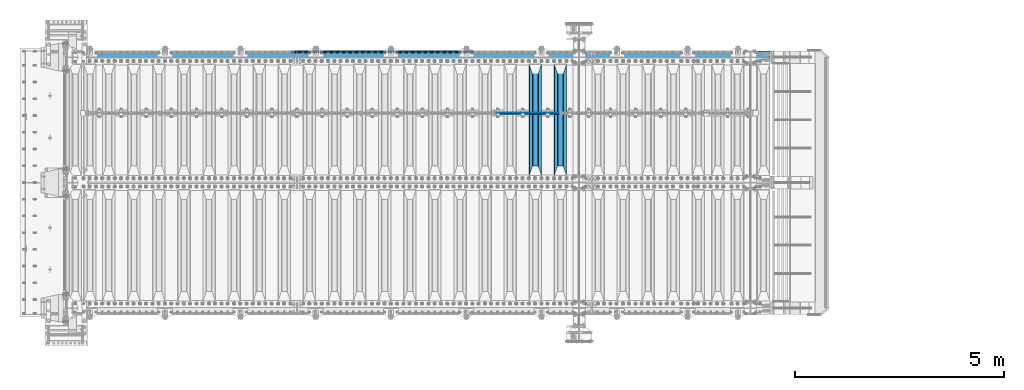
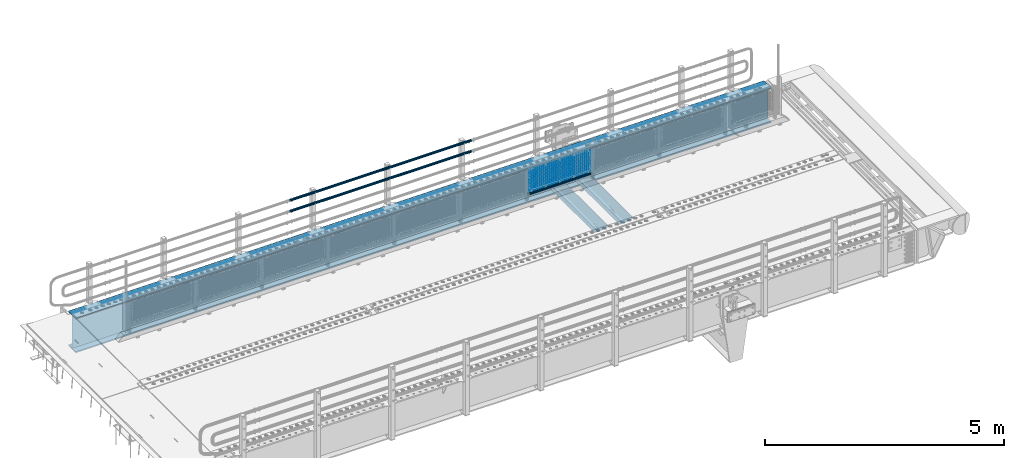
# One storey, part 105 of 208: 23 beams.
"""IFC2X3 building model written with IfcOpenShell, lengths in millimetres."""

from ifc_helpers import new_model, si_unit, frame, origin_with_axes, place, context, subcontext, project, spatial, faceted_brep, material, type_object, element, save


model = new_model("IFC2X3")

# Units and contexts
model_context = context("Model", 3, precision=1e-05, world=origin_with_axes())
body_context = subcontext(model_context, "Body", "Model", "MODEL_VIEW")
ifc_project = project(units=[si_unit("LENGTHUNIT", "METRE", prefix="MILLI"), si_unit("AREAUNIT", "SQUARE_METRE"), si_unit("VOLUMEUNIT", "CUBIC_METRE"), si_unit("MASSUNIT", "GRAM", prefix="KILO"), si_unit("TIMEUNIT", "SECOND"), si_unit("PLANEANGLEUNIT", "RADIAN"), si_unit("SOLIDANGLEUNIT", "STERADIAN"), si_unit("THERMODYNAMICTEMPERATUREUNIT", "DEGREE_CELSIUS"), si_unit("LUMINOUSINTENSITYUNIT", "LUMEN")], contexts=[model_context])

# Site, building, storey
site_placement = place(None, origin_with_axes())
site = spatial("IfcSite", under=ifc_project, at=site_placement, CompositionType="ELEMENT")
building_placement = place(site_placement, origin_with_axes())
building = spatial("IfcBuilding", under=site, at=building_placement, Name="Standard", CompositionType="ELEMENT")
storey_placement = place(building_placement, origin_with_axes())
storey = spatial("IfcBuildingStorey", under=building, at=storey_placement, Name="Undefined", CompositionType="ELEMENT", Elevation=0.0)

# Beams
ifc_material_1 = material(Name="STEEL/S355N")
beam_type_1 = type_object("IfcBeamType", PredefinedType="NOTDEFINED")
beam_1_placement = place(storey_placement, frame((-30650.0, 3175.0, -115.0), z_axis=(0.0, 0.0, 1.0), x_axis=(0.0, 1.0, 0.0)))
element("IfcBeam", 1, at=beam_1_placement, inside=storey, type_object=beam_type_1, material=ifc_material_1, context=body_context, shape_type="Brep", body=[
    faceted_brep([(0.0, 150.0, 115.0), (0.0, 143.689999999999, 115.0), (2650.00000000297, 143.689999999999, 115.0), (2650.00000000297, 150.0, 115.0), (2650.00000000297, 142.059565218402, 110.0000000031), (2650.00000000297, 148.369565218403, 110.0000000031), (2441.90079219208, -80.1103600731112, -98.0992078077845), (2437.7588105432, -77.5672621345584, -102.241189456673), (2434.06523489746, -74.4080125315522, -105.934765102404), (2430.91086095089, -70.710272125576, -109.089139048974), (2428.37322971128, -66.5649389910068, -111.626770288588), (2426.51472138055, -62.0739139532889, -113.485278619323), (2425.38102192091, -57.3475956567672, -114.618978078955), (2424.99999999987, -52.5021667386536, -115.0), (2424.99999999987, 52.5021667386536, -115.0), (2425.38102192091, 57.3475956567672, -114.618978078955), (2426.51472138055, 62.0739139532889, -113.485278619323), (2428.37322971128, 66.5649389910068, -111.626770288588), (2430.91086095089, 70.710272125576, -109.089139048974), (2434.06523489746, 74.4080125315522, -105.934765102404), (2437.7588105432, 77.5672621345584, -102.241189456673), (2441.90079219208, 80.1103600731112, -98.0992078077846), (2446.38936140511, 81.9747917625791, -93.6106385947584), (2448.24948500409, 76.2713538057251, -91.7505149957729), (2444.62967112262, 74.76777986261, -95.3703288772456), (2441.28936334126, 72.7168944282894, -98.710636658607), (2438.31067330438, 70.1691124903846, -101.689326695487), (2435.76682334747, 67.1870637758839, -104.233176652398), (2433.72034654133, 63.8440531834895, -106.279653458539), (2432.22154950041, 60.222258798236, -107.778450499454), (2431.30727574265, 56.4107117849089, -108.692724257221), (2430.99999999987, 52.5031078186876, -109.0), (2430.99999999987, -52.5031078186876, -109.0), (2431.30727574265, -56.4107117849089, -108.692724257221), (2432.22154950041, -60.222258798236, -107.778450499454), (2433.72034654133, -63.8440531834895, -106.279653458539), (2435.76682334747, -67.1870637758839, -104.233176652398), (2438.31067330438, -70.1691124903846, -101.689326695487), (2441.28936334126, -72.7168944282894, -98.7106366586071), (2444.62967112262, -74.76777986261, -95.3703288772457), (2448.24948500409, -76.2713538057251, -91.7505149957729), (2650.00000000297, -142.059565218402, 110.0000000031), (2650.00000000297, -148.369565218403, 110.0000000031), (2446.38936140511, -81.9747917625791, -93.6106385947584), (2650.00000000297, -143.689999999999, 115.0), (2650.00000000297, -150.0, 115.0), (0.0, -143.689999999999, 115.0), (0.0, -150.0, 115.0), (0.0, -148.369565218261, 110.000000002663), (203.610638597421, -81.9747917625791, -93.6106385947584), (208.099207810448, -80.1103600731112, -98.0992078077845), (212.241189459336, -77.5672621345584, -102.241189456673), (215.934765105067, -74.4080125315522, -105.934765102404), (219.089139051637, -70.710272125576, -109.089139048974), (221.626770291251, -66.5649389910068, -111.626770288588), (223.485278621986, -62.0739139532889, -113.485278619323), (224.618978081618, -57.3475956567672, -114.618978078955), (225.000000002663, -52.5021667386536, -115.0), (225.000000002663, 52.5021667386536, -115.0), (224.618978081618, 57.3475956567672, -114.618978078955), (223.485278621986, 62.0739139532889, -113.485278619323), (221.626770291251, 66.5649389910068, -111.626770288588), (219.089139051637, 70.710272125576, -109.089139048974), (215.934765105067, 74.4080125315522, -105.934765102404), (212.241189459336, 77.5672621345584, -102.241189456673), (208.099207810448, 80.1103600731112, -98.0992078077846), (203.610638597421, 81.9747917625791, -93.6106385947584), (0.0, 148.369565218261, 110.000000002663), (0.0, 142.05956521826, 110.000000002663), (201.750514998436, 76.2713538057251, -91.7505149957729), (205.370328879908, 74.76777986261, -95.3703288772456), (208.71063666127, 72.7168944282894, -98.710636658607), (211.68932669815, 70.1691124903846, -101.689326695487), (214.233176655061, 67.1870637758839, -104.233176652398), (216.279653461202, 63.8440531834895, -106.279653458539), (217.778450502116, 60.222258798236, -107.778450499454), (218.692724259884, 56.4107117849089, -108.692724257221), (219.000000002663, 52.5031078186876, -109.0), (219.000000002663, -52.5031078186876, -109.0), (218.692724259884, -56.4107117849089, -108.692724257221), (217.778450502116, -60.222258798236, -107.778450499454), (216.279653461202, -63.8440531834895, -106.279653458539), (214.233176655061, -67.1870637758839, -104.233176652398), (211.68932669815, -70.1691124903846, -101.689326695487), (208.71063666127, -72.7168944282894, -98.7106366586071), (205.370328879908, -74.76777986261, -95.3703288772457), (201.750514998436, -76.2713538057251, -91.7505149957729), (0.0, -142.05956521826, 110.000000002663)], [[[0, 1, 2, 3]], [[3, 2, 4, 5]], [[6, 7, 8, 9, 10, 11, 12, 13, 14, 15, 16, 17, 18, 19, 20, 21, 22, 5, 4, 23, 24, 25, 26, 27, 28, 29, 30, 31, 32, 33, 34, 35, 36, 37, 38, 39, 40, 41, 42, 43]], [[44, 45, 42, 41]], [[46, 47, 45, 44]], [[43, 42, 45, 47, 48, 49]], [[6, 43, 49, 50]], [[7, 6, 50, 51]], [[8, 7, 51, 52]], [[9, 8, 52, 53]], [[10, 9, 53, 54]], [[11, 10, 54, 55]], [[12, 11, 55, 56]], [[13, 12, 56, 57]], [[14, 13, 57, 58]], [[15, 14, 58, 59]], [[16, 15, 59, 60]], [[17, 16, 60, 61]], [[18, 17, 61, 62]], [[19, 18, 62, 63]], [[20, 19, 63, 64]], [[21, 20, 64, 65]], [[22, 21, 65, 66]], [[0, 3, 5, 22, 66, 67]], [[1, 0, 67, 68]], [[23, 4, 2, 1, 68, 69]], [[24, 23, 69, 70]], [[25, 24, 70, 71]], [[26, 25, 71, 72]], [[27, 26, 72, 73]], [[28, 27, 73, 74]], [[29, 28, 74, 75]], [[30, 29, 75, 76]], [[31, 30, 76, 77]], [[32, 31, 77, 78]], [[33, 32, 78, 79]], [[34, 33, 79, 80]], [[35, 34, 80, 81]], [[36, 35, 81, 82]], [[37, 36, 82, 83]], [[38, 37, 83, 84]], [[39, 38, 84, 85]], [[40, 39, 85, 86]], [[46, 44, 41, 40, 86, 87]], [[47, 46, 87, 48]], [[86, 85, 84, 83, 82, 81, 80, 79, 78, 77, 76, 75, 74, 73, 72, 71, 70, 69, 68, 67, 66, 65, 64, 63, 62, 61, 60, 59, 58, 57, 56, 55, 54, 53, 52, 51, 50, 49, 48, 87]]]),
])
beam_2_placement = place(storey_placement, frame((-31250.0, 3175.0, -115.0), z_axis=(0.0, 0.0, 1.0), x_axis=(0.0, 1.0, 0.0)))
element("IfcBeam", 2, at=beam_2_placement, inside=storey, type_object=beam_type_1, material=ifc_material_1, context=body_context, shape_type="Brep", body=[
    faceted_brep([(0.0, 150.0, 115.0), (0.0, 143.689999999999, 115.0), (2650.00000000297, 143.689999999999, 115.0), (2650.00000000297, 150.0, 115.0), (2650.00000000297, 142.059565218402, 110.0000000031), (2650.00000000297, 148.369565218403, 110.0000000031), (2441.90079219208, -80.1103600731112, -98.0992078077845), (2437.7588105432, -77.5672621345584, -102.241189456673), (2434.06523489746, -74.4080125315522, -105.934765102404), (2430.91086095089, -70.710272125576, -109.089139048974), (2428.37322971128, -66.5649389910068, -111.626770288588), (2426.51472138055, -62.0739139532889, -113.485278619323), (2425.38102192091, -57.3475956567672, -114.618978078955), (2424.99999999987, -52.5021667386536, -115.0), (2424.99999999987, 52.5021667386536, -115.0), (2425.38102192091, 57.3475956567672, -114.618978078955), (2426.51472138055, 62.0739139532889, -113.485278619323), (2428.37322971128, 66.5649389910068, -111.626770288588), (2430.91086095089, 70.710272125576, -109.089139048974), (2434.06523489746, 74.4080125315522, -105.934765102404), (2437.7588105432, 77.5672621345584, -102.241189456673), (2441.90079219208, 80.1103600731112, -98.0992078077846), (2446.38936140511, 81.9747917625791, -93.6106385947584), (2448.24948500409, 76.2713538057251, -91.7505149957729), (2444.62967112262, 74.76777986261, -95.3703288772456), (2441.28936334126, 72.7168944282894, -98.710636658607), (2438.31067330438, 70.1691124903846, -101.689326695487), (2435.76682334747, 67.1870637758839, -104.233176652398), (2433.72034654133, 63.8440531834895, -106.279653458539), (2432.22154950041, 60.222258798236, -107.778450499454), (2431.30727574265, 56.4107117849089, -108.692724257221), (2430.99999999987, 52.5031078186876, -109.0), (2430.99999999987, -52.5031078186876, -109.0), (2431.30727574265, -56.4107117849089, -108.692724257221), (2432.22154950041, -60.222258798236, -107.778450499454), (2433.72034654133, -63.8440531834895, -106.279653458539), (2435.76682334747, -67.1870637758839, -104.233176652398), (2438.31067330438, -70.1691124903846, -101.689326695487), (2441.28936334126, -72.7168944282894, -98.7106366586071), (2444.62967112262, -74.76777986261, -95.3703288772457), (2448.24948500409, -76.2713538057251, -91.7505149957729), (2650.00000000297, -142.059565218402, 110.0000000031), (2650.00000000297, -148.369565218403, 110.0000000031), (2446.38936140511, -81.9747917625791, -93.6106385947584), (2650.00000000297, -143.689999999999, 115.0), (2650.00000000297, -150.0, 115.0), (0.0, -143.689999999999, 115.0), (0.0, -150.0, 115.0), (0.0, -148.369565218261, 110.000000002663), (203.610638597421, -81.9747917625791, -93.6106385947584), (208.099207810448, -80.1103600731112, -98.0992078077845), (212.241189459336, -77.5672621345584, -102.241189456673), (215.934765105067, -74.4080125315522, -105.934765102404), (219.089139051637, -70.710272125576, -109.089139048974), (221.626770291251, -66.5649389910068, -111.626770288588), (223.485278621986, -62.0739139532889, -113.485278619323), (224.618978081618, -57.3475956567672, -114.618978078955), (225.000000002663, -52.5021667386536, -115.0), (225.000000002663, 52.5021667386536, -115.0), (224.618978081618, 57.3475956567672, -114.618978078955), (223.485278621986, 62.0739139532889, -113.485278619323), (221.626770291251, 66.5649389910068, -111.626770288588), (219.089139051637, 70.710272125576, -109.089139048974), (215.934765105067, 74.4080125315522, -105.934765102404), (212.241189459336, 77.5672621345584, -102.241189456673), (208.099207810448, 80.1103600731112, -98.0992078077846), (203.610638597421, 81.9747917625791, -93.6106385947584), (0.0, 148.369565218261, 110.000000002663), (0.0, 142.05956521826, 110.000000002663), (201.750514998436, 76.2713538057251, -91.7505149957729), (205.370328879908, 74.76777986261, -95.3703288772456), (208.71063666127, 72.7168944282894, -98.710636658607), (211.68932669815, 70.1691124903846, -101.689326695487), (214.233176655061, 67.1870637758839, -104.233176652398), (216.279653461202, 63.8440531834895, -106.279653458539), (217.778450502116, 60.222258798236, -107.778450499454), (218.692724259884, 56.4107117849089, -108.692724257221), (219.000000002663, 52.5031078186876, -109.0), (219.000000002663, -52.5031078186876, -109.0), (218.692724259884, -56.4107117849089, -108.692724257221), (217.778450502116, -60.222258798236, -107.778450499454), (216.279653461202, -63.8440531834895, -106.279653458539), (214.233176655061, -67.1870637758839, -104.233176652398), (211.68932669815, -70.1691124903846, -101.689326695487), (208.71063666127, -72.7168944282894, -98.7106366586071), (205.370328879908, -74.76777986261, -95.3703288772457), (201.750514998436, -76.2713538057251, -91.7505149957729), (0.0, -142.05956521826, 110.000000002663)], [[[0, 1, 2, 3]], [[3, 2, 4, 5]], [[6, 7, 8, 9, 10, 11, 12, 13, 14, 15, 16, 17, 18, 19, 20, 21, 22, 5, 4, 23, 24, 25, 26, 27, 28, 29, 30, 31, 32, 33, 34, 35, 36, 37, 38, 39, 40, 41, 42, 43]], [[44, 45, 42, 41]], [[46, 47, 45, 44]], [[43, 42, 45, 47, 48, 49]], [[6, 43, 49, 50]], [[7, 6, 50, 51]], [[8, 7, 51, 52]], [[9, 8, 52, 53]], [[10, 9, 53, 54]], [[11, 10, 54, 55]], [[12, 11, 55, 56]], [[13, 12, 56, 57]], [[14, 13, 57, 58]], [[15, 14, 58, 59]], [[16, 15, 59, 60]], [[17, 16, 60, 61]], [[18, 17, 61, 62]], [[19, 18, 62, 63]], [[20, 19, 63, 64]], [[21, 20, 64, 65]], [[22, 21, 65, 66]], [[0, 3, 5, 22, 66, 67]], [[1, 0, 67, 68]], [[23, 4, 2, 1, 68, 69]], [[24, 23, 69, 70]], [[25, 24, 70, 71]], [[26, 25, 71, 72]], [[27, 26, 72, 73]], [[28, 27, 73, 74]], [[29, 28, 74, 75]], [[30, 29, 75, 76]], [[31, 30, 76, 77]], [[32, 31, 77, 78]], [[33, 32, 78, 79]], [[34, 33, 79, 80]], [[35, 34, 80, 81]], [[36, 35, 81, 82]], [[37, 36, 82, 83]], [[38, 37, 83, 84]], [[39, 38, 84, 85]], [[40, 39, 85, 86]], [[46, 44, 41, 40, 86, 87]], [[47, 46, 87, 48]], [[86, 85, 84, 83, 82, 81, 80, 79, 78, 77, 76, 75, 74, 73, 72, 71, 70, 69, 68, 67, 66, 65, 64, 63, 62, 61, 60, 59, 58, 57, 56, 55, 54, 53, 52, 51, 50, 49, 48, 87]]]),
])
ifc_material_2 = material(Name="Misc_Undefined")
beam_type_2 = type_object("IfcBeamType", Name="D3", PredefinedType="NOTDEFINED")
for number, where, z_axis, x_axis in (
    (3, (-32174.0, 4670.5, 851.597000000004), (0.0, 0.0, 1.0), (1.0, 0.0, 0.0)),
    (4, (-32174.0, 4670.5, 669.452000000004), (0.0, 0.0, 1.0), (1.0, 0.0, 0.0)),
    (5, (-32174.0, 4670.5, 523.736000000004), (0.0, 0.0, 1.0), (1.0, 0.0, 0.0)),
    (6, (-32174.0, 4670.5, 487.307000000004), (0.0, 0.0, 1.0), (1.0, 0.0, 0.0)),
    (7, (-32174.0, 4670.5, 705.881000000004), (0.0, 0.0, 1.0), (1.0, 0.0, 0.0)),
    (8, (-32174.0, 4670.5, 596.594000000004), (0.0, 0.0, 1.0), (1.0, 0.0, 0.0)),
    (9, (-32174.0, 4670.5, 450.878000000004), (0.0, 0.0, 1.0), (1.0, 0.0, 0.0)),
    (10, (-32174.0, 4670.5, 815.168000000004), (0.0, 0.0, 1.0), (1.0, 0.0, 0.0)),
    (11, (-32174.0, 4670.5, 888.026000000004), (0.0, 0.0, 1.0), (1.0, 0.0, 0.0)),
    (12, (-32174.0, 4670.5, 778.739000000004), (0.0, 0.0, 1.0), (1.0, 0.0, 0.0)),
    (13, (-32174.0, 4670.5, 742.310000000004), (0.0, 0.0, 1.0), (1.0, 0.0, 0.0)),
    (14, (-32174.0, 4670.5, 633.023000000004), (0.0, 0.0, 1.0), (1.0, 0.0, 0.0)),
    (15, (-32174.0, 4670.5, 560.165000000004), (0.0, 0.0, 1.0), (1.0, 0.0, 0.0)),
    (16, (-32174.0, 4670.5, 414.449000000004), (0.0, 0.0, 1.0), (1.0, 0.0, 0.0)),
):
    element("IfcBeam", number, at=place(storey_placement, frame(where, z_axis=z_axis, x_axis=x_axis)), inside=storey, type_object=beam_type_2, material=ifc_material_2, ObjectType="D3", context=body_context, shape_type="Brep", body=[
        faceted_brep([(0.0, -1.49999999999909, 3.63797880709171e-12), (-7.27595761418343e-12, -0.749999999999091, -1.29903810567669), (1490.0, -0.75, -1.29903810567669), (1490.0, -1.5, 0.0), (-3.63797880709171e-12, 0.750000000000909, -1.29903810567669), (1490.0, 0.75, -1.29903810567669), (0.0, 1.50000000000182, 3.63797880709171e-12), (1490.0, 1.5, 0.0), (-3.63797880709171e-12, 0.750000000000909, 1.29903810567669), (1490.0, 0.75, 1.29903810567669), (-7.27595761418343e-12, -0.749999999999091, 1.29903810567669), (1490.0, -0.75, 1.29903810567669)], [[[0, 1, 2, 3]], [[1, 4, 5, 2]], [[4, 6, 7, 5]], [[6, 8, 9, 7]], [[8, 10, 11, 9]], [[10, 0, 3, 11]], [[5, 7, 9, 11, 3, 2]], [[10, 8, 6, 4, 1, 0]]]),
    ])
beam_3_placement = place(storey_placement, frame((-32149.0, 4670.5, 353.020000000004), z_axis=(0.0, 0.0, 1.0), x_axis=(1.0, 0.0, 0.0)))
element("IfcBeam", 17, at=beam_3_placement, inside=storey, type_object=beam_type_2, material=ifc_material_2, ObjectType="D3", context=body_context, shape_type="Brep", body=[
    faceted_brep([(0.0, -1.49999999999909, 3.63797880709171e-12), (-7.27595761418343e-12, -0.749999999999091, -1.29903810567669), (1440.0, -0.75, -1.29903810567669), (1440.0, -1.5, 0.0), (-3.63797880709171e-12, 0.750000000000909, -1.29903810567669), (1440.0, 0.75, -1.29903810567663), (0.0, 1.50000000000182, 3.63797880709171e-12), (1440.0, 1.5, 0.0), (-3.63797880709171e-12, 0.750000000000909, 1.29903810567669), (1440.0, 0.75, 1.29903810567669), (-7.27595761418343e-12, -0.749999999999091, 1.29903810567669), (1440.0, -0.75, 1.29903810567669)], [[[0, 1, 2, 3]], [[1, 4, 5, 2]], [[4, 6, 7, 5]], [[6, 8, 9, 7]], [[8, 10, 11, 9]], [[10, 0, 3, 11]], [[5, 7, 9, 11, 3, 2]], [[10, 8, 6, 4, 1, 0]]]),
])
beam_4_placement = place(storey_placement, frame((-32174.0, 4670.5, 378.020000000004), z_axis=(0.0, 0.0, 1.0), x_axis=(1.0, 0.0, 0.0)))
element("IfcBeam", 18, at=beam_4_placement, inside=storey, type_object=beam_type_2, material=ifc_material_2, ObjectType="D3", context=body_context, shape_type="Brep", body=[
    faceted_brep([(0.0, -1.49999999999909, 3.63797880709171e-12), (-7.27595761418343e-12, -0.749999999999091, -1.29903810567669), (1490.0, -0.75, -1.29903810567669), (1490.0, -1.5, 0.0), (-3.63797880709171e-12, 0.750000000000909, -1.29903810567669), (1490.0, 0.75, -1.29903810567669), (0.0, 1.50000000000182, 3.63797880709171e-12), (1490.0, 1.5, 0.0), (-3.63797880709171e-12, 0.750000000000909, 1.29903810567669), (1490.0, 0.75, 1.29903810567669), (-7.27595761418343e-12, -0.749999999999091, 1.29903810567669), (1490.0, -0.75, 1.29903810567669)], [[[0, 1, 2, 3]], [[1, 4, 5, 2]], [[4, 6, 7, 5]], [[6, 8, 9, 7]], [[8, 10, 11, 9]], [[10, 0, 3, 11]], [[5, 7, 9, 11, 3, 2]], [[10, 8, 6, 4, 1, 0]]]),
])
beam_5_placement = place(storey_placement, frame((-32149.0, 4670.5, 913.020000000004), z_axis=(0.0, 0.0, 1.0), x_axis=(1.0, 0.0, 0.0)))
element("IfcBeam", 19, at=beam_5_placement, inside=storey, type_object=beam_type_2, material=ifc_material_2, ObjectType="D3", context=body_context, shape_type="Brep", body=[
    faceted_brep([(0.0, -1.49999999999909, 3.63797880709171e-12), (-7.27595761418343e-12, -0.749999999999091, -1.29903810567669), (1440.0, -0.75, -1.29903810567669), (1440.0, -1.5, 0.0), (-3.63797880709171e-12, 0.750000000000909, -1.29903810567669), (1440.0, 0.75, -1.29903810567663), (0.0, 1.50000000000182, 3.63797880709171e-12), (1440.0, 1.5, 0.0), (-3.63797880709171e-12, 0.750000000000909, 1.29903810567669), (1440.0, 0.75, 1.29903810567669), (-7.27595761418343e-12, -0.749999999999091, 1.29903810567669), (1440.0, -0.75, 1.29903810567669)], [[[0, 1, 2, 3]], [[1, 4, 5, 2]], [[4, 6, 7, 5]], [[6, 8, 9, 7]], [[8, 10, 11, 9]], [[10, 0, 3, 11]], [[5, 7, 9, 11, 3, 2]], [[10, 8, 6, 4, 1, 0]]]),
])
ifc_material_3 = material()
beam_type_3 = type_object("IfcBeamType", PredefinedType="NOTDEFINED")
beam_6_placement = place(storey_placement, frame((-32194.15, 4664.5, 298.170000000005), z_axis=(0.0, 0.0, 1.0), x_axis=(1.0, 0.0, 0.0)))
element("IfcBeam", 20, at=beam_6_placement, inside=storey, type_object=beam_type_3, material=ifc_material_3, context=body_context, shape_type="Brep", body=[
    faceted_brep([(0.0, -25.3500000000004, 0.0), (0.0, -23.4203461491616, 9.70102501045403), (1530.0, -23.4203461491616, 9.70102501045506), (1530.0, -25.3500000000004, 0.0), (0.0, -17.9251569030794, 17.9251569030785), (1530.0, -17.9251569030794, 17.925156903079), (0.0, -9.70102501045494, 23.4203461491597), (1530.0, -9.70102501045494, 23.4203461491611), (0.0, 0.0, 25.3499999999985), (1530.0, 0.0, 25.35), (0.0, 9.70102501045494, 23.4203461491597), (1530.0, 9.70102501045494, 23.4203461491611), (0.0, 17.9251569030794, 17.9251569030785), (1530.0, 17.9251569030794, 17.925156903079), (0.0, 23.4203461491616, 9.70102501045403), (1530.0, 23.4203461491616, 9.701025010455), (0.0, 25.3500000000004, 0.0), (1530.0, 25.3500000000004, 0.0), (0.0, 23.4203461491616, -9.70102501045403), (1530.0, 23.4203461491616, -9.70102501045506), (0.0, 17.9251569030794, -17.9251569030785), (1530.0, 17.9251569030794, -17.925156903079), (0.0, 9.70102501045494, -23.4203461491597), (1530.0, 9.70102501045494, -23.4203461491611), (0.0, 0.0, -25.3499999999985), (1530.0, 0.0, -25.35), (0.0, -9.70102501045494, -23.4203461491597), (1530.0, -9.70102501045494, -23.4203461491611), (0.0, -17.9251569030794, -17.9251569030785), (1530.0, -17.9251569030794, -17.925156903079), (0.0, -23.4203461491616, -9.70102501045403), (1530.0, -23.4203461491616, -9.701025010455), (0.0, -30.1499999999996, 0.0), (0.0, -27.8549679052148, -11.5379054858058), (1530.0, -27.8549679052148, -11.5379054858075), (1530.0, -30.1499999999996, 0.0), (0.0, -21.3192694527743, -21.3192694527752), (1530.0, -21.3192694527743, -21.3192694527744), (0.0, -11.5379054858076, -27.8549679052157), (1530.0, -11.5379054858076, -27.8549679052153), (0.0, 0.0, -30.1500000000015), (1530.0, 0.0, -30.15), (0.0, 11.5379054858076, -27.8549679052157), (1530.0, 11.5379054858076, -27.8549679052153), (0.0, 21.3192694527743, -21.3192694527752), (1530.0, 21.3192694527743, -21.3192694527744), (0.0, 27.8549679052157, -11.5379054858058), (1530.0, 27.8549679052157, -11.5379054858075), (0.0, 30.1499999999996, 0.0), (1530.0, 30.1499999999996, 0.0), (0.0, 27.8549679052157, 11.5379054858058), (1530.0, 27.8549679052157, 11.5379054858075), (0.0, 21.3192694527743, 21.3192694527752), (1530.0, 21.3192694527743, 21.3192694527744), (0.0, 11.5379054858076, 27.8549679052157), (1530.0, 11.5379054858076, 27.8549679052153), (0.0, 0.0, 30.1500000000015), (1530.0, 0.0, 30.15), (0.0, -11.5379054858076, 27.8549679052157), (1530.0, -11.5379054858076, 27.8549679052153), (0.0, -21.3192694527743, 21.3192694527752), (1530.0, -21.3192694527743, 21.3192694527744), (0.0, -27.8549679052157, 11.5379054858058), (1530.0, -27.8549679052157, 11.5379054858075)], [[[0, 1, 2, 3]], [[1, 4, 5, 2]], [[4, 6, 7, 5]], [[6, 8, 9, 7]], [[8, 10, 11, 9]], [[10, 12, 13, 11]], [[12, 14, 15, 13]], [[14, 16, 17, 15]], [[16, 18, 19, 17]], [[18, 20, 21, 19]], [[20, 22, 23, 21]], [[22, 24, 25, 23]], [[24, 26, 27, 25]], [[26, 28, 29, 27]], [[28, 30, 31, 29]], [[30, 0, 3, 31]], [[32, 33, 34, 35]], [[33, 36, 37, 34]], [[36, 38, 39, 37]], [[38, 40, 41, 39]], [[40, 42, 43, 41]], [[42, 44, 45, 43]], [[44, 46, 47, 45]], [[46, 48, 49, 47]], [[48, 50, 51, 49]], [[50, 52, 53, 51]], [[52, 54, 55, 53]], [[54, 56, 57, 55]], [[56, 58, 59, 57]], [[58, 60, 61, 59]], [[60, 62, 63, 61]], [[62, 32, 35, 63]], [[37, 39, 41, 43, 45, 47, 49, 51, 53, 55, 57, 59, 61, 63, 35, 34], [5, 7, 9, 11, 13, 15, 17, 19, 21, 23, 25, 27, 29, 31, 3, 2]], [[62, 60, 58, 56, 54, 52, 50, 48, 46, 44, 42, 40, 38, 36, 33, 32], [30, 28, 26, 24, 22, 20, 18, 16, 14, 12, 10, 8, 6, 4, 1, 0]]]),
])
beam_type_4 = type_object("IfcBeamType", PredefinedType="NOTDEFINED")
beam_7_placement = place(storey_placement, frame((-32722.0000000001, 6129.85000000009, 969.849999999725), z_axis=(0.0, 0.0, -1.0), x_axis=(-1.0, 0.0, 0.0)))
element("IfcBeam", 21, at=beam_7_placement, inside=storey, type_object=beam_type_4, material=ifc_material_3, context=body_context, shape_type="Brep", body=[
    faceted_brep([(0.0, -26.5500000000002, 0.0), (0.0, -24.5290015881747, 10.1602451292931), (4384.00249699992, -24.5290015881747, 10.1602451292931), (4384.00249699992, -26.5500000000002, 0.0), (0.0, -18.7736850405026, 18.7736850405028), (4384.00249699992, -18.7736850405026, 18.7736850405028), (0.0, -10.1602451292929, 24.5290015881747), (4384.00249699992, -10.1602451292929, 24.5290015881747), (0.0, 0.0, 26.55), (4384.00249699992, 0.0, 26.55), (0.0, 10.1602451292929, 24.5290015881747), (4384.00249699992, 10.1602451292929, 24.5290015881747), (0.0, 18.7736850405026, 18.7736850405028), (4384.00249699992, 18.7736850405026, 18.7736850405028), (0.0, 24.5290015881747, 10.1602451292931), (4384.00249699992, 24.5290015881747, 10.1602451292931), (0.0, 26.5500000000002, 0.0), (4384.00249699992, 26.5500000000002, 0.0), (0.0, 24.5290015881747, -10.1602451292931), (4384.00249699992, 24.5290015881747, -10.1602451292931), (0.0, 18.7736850405026, -18.7736850405028), (4384.00249699992, 18.7736850405026, -18.7736850405028), (0.0, 10.1602451292929, -24.5290015881747), (4384.00249699992, 10.1602451292929, -24.5290015881747), (0.0, 0.0, -26.55), (4384.00249699992, 0.0, -26.55), (0.0, -10.1602451292929, -24.5290015881747), (4384.00249699992, -10.1602451292929, -24.5290015881747), (0.0, -18.7736850405026, -18.7736850405028), (4384.00249699992, -18.7736850405026, -18.7736850405028), (0.0, -24.5290015881747, -10.1602451292931), (4384.00249699992, -24.5290015881747, -10.1602451292931), (0.0, -30.1499999999996, 0.0), (0.0, -27.8549679052148, -11.5379054858058), (4384.00249699992, -27.8549679052148, -11.5379054858075), (4384.00249699992, -30.1499999999996, 0.0), (0.0, -21.3192694527743, -21.3192694527752), (4384.00249699992, -21.3192694527743, -21.3192694527744), (0.0, -11.5379054858076, -27.8549679052157), (4384.00249699992, -11.5379054858076, -27.8549679052153), (0.0, 0.0, -30.1500000000015), (4384.00249699992, 0.0, -30.15), (0.0, 11.5379054858076, -27.8549679052157), (4384.00249699992, 11.5379054858076, -27.8549679052153), (0.0, 21.3192694527743, -21.3192694527752), (4384.00249699992, 21.3192694527743, -21.3192694527744), (0.0, 27.8549679052157, -11.5379054858058), (4384.00249699992, 27.8549679052157, -11.5379054858074), (0.0, 30.1499999999996, 0.0), (4384.00249699992, 30.1499999999996, 0.0), (0.0, 27.8549679052157, 11.5379054858058), (4384.00249699992, 27.8549679052157, 11.5379054858075), (0.0, 21.3192694527743, 21.3192694527752), (4384.00249699992, 21.3192694527743, 21.3192694527744), (0.0, 11.5379054858076, 27.8549679052157), (4384.00249699992, 11.5379054858076, 27.8549679052153), (0.0, 0.0, 30.1500000000015), (4384.00249699992, 0.0, 30.15), (0.0, -11.5379054858076, 27.8549679052157), (4384.00249699992, -11.5379054858076, 27.8549679052153), (0.0, -21.3192694527743, 21.3192694527752), (4384.00249699992, -21.3192694527743, 21.3192694527744), (0.0, -27.8549679052157, 11.5379054858058), (4384.00249699992, -27.8549679052157, 11.5379054858075)], [[[0, 1, 2, 3]], [[1, 4, 5, 2]], [[4, 6, 7, 5]], [[6, 8, 9, 7]], [[8, 10, 11, 9]], [[10, 12, 13, 11]], [[12, 14, 15, 13]], [[14, 16, 17, 15]], [[16, 18, 19, 17]], [[18, 20, 21, 19]], [[20, 22, 23, 21]], [[22, 24, 25, 23]], [[24, 26, 27, 25]], [[26, 28, 29, 27]], [[28, 30, 31, 29]], [[30, 0, 3, 31]], [[32, 33, 34, 35]], [[33, 36, 37, 34]], [[36, 38, 39, 37]], [[38, 40, 41, 39]], [[40, 42, 43, 41]], [[42, 44, 45, 43]], [[44, 46, 47, 45]], [[46, 48, 49, 47]], [[48, 50, 51, 49]], [[50, 52, 53, 51]], [[52, 54, 55, 53]], [[54, 56, 57, 55]], [[56, 58, 59, 57]], [[58, 60, 61, 59]], [[60, 62, 63, 61]], [[62, 32, 35, 63]], [[37, 39, 41, 43, 45, 47, 49, 51, 53, 55, 57, 59, 61, 63, 35, 34], [5, 7, 9, 11, 13, 15, 17, 19, 21, 23, 25, 27, 29, 31, 3, 2]], [[62, 60, 58, 56, 54, 52, 50, 48, 46, 44, 42, 40, 38, 36, 33, 32], [30, 28, 26, 24, 22, 20, 18, 16, 14, 12, 10, 8, 6, 4, 1, 0]]]),
])
beam_8_placement = place(storey_placement, frame((-32722.0000000001, 6129.85000000009, 689.849999999725), z_axis=(0.0, 0.0, -1.0), x_axis=(-1.0, 0.0, 0.0)))
element("IfcBeam", 22, at=beam_8_placement, inside=storey, type_object=beam_type_4, material=ifc_material_3, context=body_context, shape_type="Brep", body=[
    faceted_brep([(0.0, -26.5500000000002, 0.0), (0.0, -24.5290015881747, 10.1602451292931), (4384.00249699992, -24.5290015881747, 10.1602451292931), (4384.00249699992, -26.5500000000002, 0.0), (0.0, -18.7736850405026, 18.7736850405028), (4384.00249699992, -18.7736850405026, 18.7736850405028), (0.0, -10.1602451292929, 24.5290015881747), (4384.00249699992, -10.1602451292929, 24.5290015881747), (0.0, 0.0, 26.55), (4384.00249699992, 0.0, 26.55), (0.0, 10.1602451292929, 24.5290015881747), (4384.00249699992, 10.1602451292929, 24.5290015881747), (0.0, 18.7736850405026, 18.7736850405028), (4384.00249699992, 18.7736850405026, 18.7736850405028), (0.0, 24.5290015881747, 10.1602451292931), (4384.00249699992, 24.5290015881747, 10.1602451292931), (0.0, 26.5500000000002, 0.0), (4384.00249699992, 26.5500000000002, 0.0), (0.0, 24.5290015881747, -10.1602451292931), (4384.00249699992, 24.5290015881747, -10.1602451292931), (0.0, 18.7736850405026, -18.7736850405028), (4384.00249699992, 18.7736850405026, -18.7736850405028), (0.0, 10.1602451292929, -24.5290015881747), (4384.00249699992, 10.1602451292929, -24.5290015881747), (0.0, 0.0, -26.55), (4384.00249699992, 0.0, -26.55), (0.0, -10.1602451292929, -24.5290015881747), (4384.00249699992, -10.1602451292929, -24.5290015881747), (0.0, -18.7736850405026, -18.7736850405028), (4384.00249699992, -18.7736850405026, -18.7736850405028), (0.0, -24.5290015881747, -10.1602451292931), (4384.00249699992, -24.5290015881747, -10.1602451292931), (0.0, -30.1499999999996, 0.0), (0.0, -27.8549679052148, -11.5379054858058), (4384.00249699992, -27.8549679052148, -11.5379054858075), (4384.00249699992, -30.1499999999996, 0.0), (0.0, -21.3192694527743, -21.3192694527752), (4384.00249699992, -21.3192694527743, -21.3192694527744), (0.0, -11.5379054858076, -27.8549679052157), (4384.00249699992, -11.5379054858076, -27.8549679052153), (0.0, 0.0, -30.1500000000015), (4384.00249699992, 0.0, -30.15), (0.0, 11.5379054858076, -27.8549679052157), (4384.00249699992, 11.5379054858076, -27.8549679052153), (0.0, 21.3192694527743, -21.3192694527752), (4384.00249699992, 21.3192694527743, -21.3192694527744), (0.0, 27.8549679052157, -11.5379054858058), (4384.00249699992, 27.8549679052157, -11.5379054858074), (0.0, 30.1499999999996, 0.0), (4384.00249699992, 30.1499999999996, 0.0), (0.0, 27.8549679052157, 11.5379054858058), (4384.00249699992, 27.8549679052157, 11.5379054858075), (0.0, 21.3192694527743, 21.3192694527752), (4384.00249699992, 21.3192694527743, 21.3192694527744), (0.0, 11.5379054858076, 27.8549679052157), (4384.00249699992, 11.5379054858076, 27.8549679052153), (0.0, 0.0, 30.1500000000015), (4384.00249699992, 0.0, 30.15), (0.0, -11.5379054858076, 27.8549679052157), (4384.00249699992, -11.5379054858076, 27.8549679052153), (0.0, -21.3192694527743, 21.3192694527752), (4384.00249699992, -21.3192694527743, 21.3192694527744), (0.0, -27.8549679052157, 11.5379054858058), (4384.00249699992, -27.8549679052157, 11.5379054858075)], [[[0, 1, 2, 3]], [[1, 4, 5, 2]], [[4, 6, 7, 5]], [[6, 8, 9, 7]], [[8, 10, 11, 9]], [[10, 12, 13, 11]], [[12, 14, 15, 13]], [[14, 16, 17, 15]], [[16, 18, 19, 17]], [[18, 20, 21, 19]], [[20, 22, 23, 21]], [[22, 24, 25, 23]], [[24, 26, 27, 25]], [[26, 28, 29, 27]], [[28, 30, 31, 29]], [[30, 0, 3, 31]], [[32, 33, 34, 35]], [[33, 36, 37, 34]], [[36, 38, 39, 37]], [[38, 40, 41, 39]], [[40, 42, 43, 41]], [[42, 44, 45, 43]], [[44, 46, 47, 45]], [[46, 48, 49, 47]], [[48, 50, 51, 49]], [[50, 52, 53, 51]], [[52, 54, 55, 53]], [[54, 56, 57, 55]], [[56, 58, 59, 57]], [[58, 60, 61, 59]], [[60, 62, 63, 61]], [[62, 32, 35, 63]], [[37, 39, 41, 43, 45, 47, 49, 51, 53, 55, 57, 59, 61, 63, 35, 34], [5, 7, 9, 11, 13, 15, 17, 19, 21, 23, 25, 27, 29, 31, 3, 2]], [[62, 60, 58, 56, 54, 52, 50, 48, 46, 44, 42, 40, 38, 36, 33, 32], [30, 28, 26, 24, 22, 20, 18, 16, 14, 12, 10, 8, 6, 4, 1, 0]]]),
])
beam_type_5 = type_object("IfcBeamType", Name="HEA900", PredefinedType="NOTDEFINED")
beam_9_placement = place(storey_placement, frame((-42440.0, 6000.0, -445.0), z_axis=(0.0, 0.0, 1.0), x_axis=(1.0, 0.0, 0.0)))
element("IfcBeam", 23, at=beam_9_placement, inside=storey, type_object=beam_type_5, material=ifc_material_1, ObjectType="HEA900", context=body_context, shape_type="Brep", body=[
    faceted_brep([(0.0, 150.0, -445.0), (0.0, 150.0, -415.0), (16807.0, 150.0, -415.0), (16807.0, 150.0, -445.0), (0.0, 8.0, -415.0), (16807.0, 8.0, -415.0), (0.0, 8.0, 415.0), (16807.0, 8.0, 415.0), (0.0, 150.0, 415.0), (16807.0, 150.0, 415.0), (0.0, 150.0, 445.0), (16807.0, 150.0, 445.0), (0.0, -150.0, 445.0), (16807.0, -150.0, 445.0), (0.0, -150.0, 415.0), (16807.0, -150.0, 415.0), (0.0, -8.0, 415.0), (16807.0, -8.0, 415.0), (0.0, -8.0, -415.0), (16807.0, -8.0, -415.0), (0.0, -150.0, -415.0), (16807.0, -150.0, -415.0), (0.0, -150.0, -445.0), (16807.0, -150.0, -445.0)], [[[0, 1, 2, 3]], [[1, 4, 5, 2]], [[4, 6, 7, 5]], [[6, 8, 9, 7]], [[8, 10, 11, 9]], [[10, 12, 13, 11]], [[12, 14, 15, 13]], [[14, 16, 17, 15]], [[16, 18, 19, 17]], [[18, 20, 21, 19]], [[20, 22, 23, 21]], [[22, 0, 3, 23]], [[5, 7, 9, 11, 13, 15, 17, 19, 21, 23, 3, 2]], [[22, 20, 18, 16, 14, 12, 10, 8, 6, 4, 1, 0]]]),
])

save(model, "model.ifc")
